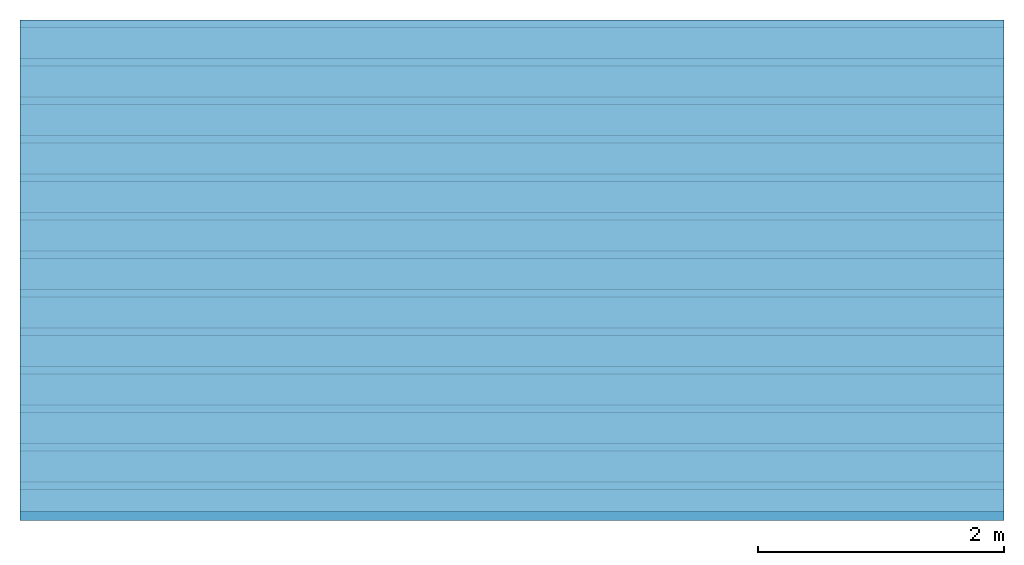
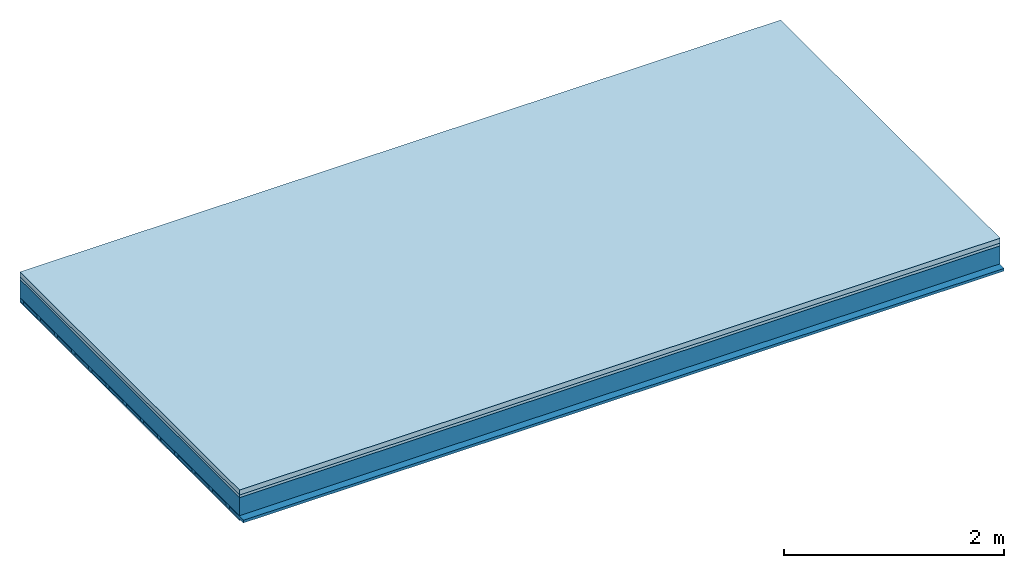
# One storey: 3 members, 3 plates, 1 element without a shape of its own.
"""IFC4 building model written with IfcOpenShell, lengths in metres."""

from ifc_helpers import new_model, si_unit, derived_unit, direction, frame, frame_2d, origin, origin_with_axes, place, context, project, spatial, rectangle, extrude, material, layer, layer_set, type_object, element, aggregate, save


model = new_model("IFC4")

# Units and contexts
plan_context = context("Plan", 3, precision=1e-05, world=origin(), true_north=direction((0.0, 1.0)))
model_context = context("Model", 3, precision=1e-05, world=origin(), true_north=direction((0.0, 1.0)))
ifc_project = project(units=[si_unit("LENGTHUNIT", "METRE"), derived_unit("SOUNDPRESSUREUNIT", [(si_unit("PRESSUREUNIT", "PASCAL", prefix="MICRO"), 0)]), si_unit("ENERGYUNIT", "JOULE", prefix="MEGA"), si_unit("MASSUNIT", "GRAM", prefix="KILO"), derived_unit("THERMALTRANSMITTANCEUNIT", [(si_unit("POWERUNIT", "WATT"), 1), (si_unit("AREAUNIT", "SQUARE_METRE"), -1), (si_unit("THERMODYNAMICTEMPERATUREUNIT", "KELVIN"), -1)]), derived_unit("AREADENSITYUNIT", [(si_unit("MASSUNIT", "GRAM", prefix="KILO"), 1), (si_unit("AREAUNIT", "SQUARE_METRE"), -1)]), derived_unit("USERDEFINED", [(si_unit("ENERGYUNIT", "JOULE", prefix="MEGA"), 1), (si_unit("AREAUNIT", "SQUARE_METRE"), -1)])], contexts=[plan_context, model_context])

# Site, building, storey
site = spatial("IfcSite", under=ifc_project)
building_placement = place(None, origin())
building = spatial("IfcBuilding", under=site, at=building_placement)
storey_placement = place(building_placement, origin())
storey = spatial("IfcBuildingStorey", under=building, at=storey_placement)

# Slab, members, plates
ifc_material_1 = material(Category="04.005")
ifc_layer_1 = layer(ifc_material_1, 0.055, Name="On-material")
ifc_material_2 = material()
ifc_layer_2 = layer(ifc_material_2, 0.03, Name="Impact sound insulation")
ifc_layer_3 = layer(None, 0.2, Name="Supporting structure")
ifc_material_3 = material(Name="of the art")
ifc_layer_4 = layer(ifc_material_3, 0.0, Name="Bond")
ifc_layer_5 = layer(None, 0.04, Name="Battens / profiles")
ifc_material_4 = material(Category="03.007")
ifc_layer_6 = layer(ifc_material_4, 0.015, Name="Ceiling covering 1st layer")
ifc_material_5 = material(Name="Glued joints")
ifc_layer_7 = layer(ifc_material_5, 0.0, Name="Surface / treatment")
ifc_layer_set = layer_set([ifc_layer_1, ifc_layer_2, ifc_layer_3, ifc_layer_4, ifc_layer_5, ifc_layer_6, ifc_layer_7])
slab_type = type_object("IfcSlabType", Name="A0849", PredefinedType="NOTDEFINED", material=ifc_layer_set)
slab_placement = place(None, frame((0.0, 0.0, 0.0), z_axis=(0.0, 0.0, -1.0), x_axis=(1.0, 0.0, 0.0)))
slab = element("IfcSlab", 1, at=slab_placement, inside=storey, type_object=slab_type, material=ifc_layer_set, Name="Slab #1")
ifc_material_6 = material()
member_1_placement = place(slab_placement, origin())
member_1 = element("IfcMember", 2, at=member_1_placement, material=ifc_material_6, Name="Supporting structure", context=plan_context, shape_type="SweptSolid", body=[
    extrude(rectangle(XDim=1.0, YDim=0.2, at=frame_2d((0.5, 0.1), x_axis=(1.0, 0.0))), frame((0.0, 4.0, 0.085), z_axis=(0.0, -1.0, 0.0), x_axis=(1.0, 0.0, 0.0)), (0.0, 0.0, 1.0), 4.0),
    extrude(rectangle(XDim=1.0, YDim=0.2, at=frame_2d((0.5, 0.1), x_axis=(1.0, 0.0))), frame((1.0, 4.0, 0.085), z_axis=(0.0, -1.0, 0.0), x_axis=(1.0, 0.0, 0.0)), (0.0, 0.0, 1.0), 4.0),
    extrude(rectangle(XDim=1.0, YDim=0.2, at=frame_2d((0.5, 0.1), x_axis=(1.0, 0.0))), frame((2.0, 4.0, 0.085), z_axis=(0.0, -1.0, 0.0), x_axis=(1.0, 0.0, 0.0)), (0.0, 0.0, 1.0), 4.0),
    extrude(rectangle(XDim=1.0, YDim=0.2, at=frame_2d((0.5, 0.1), x_axis=(1.0, 0.0))), frame((3.0, 4.0, 0.085), z_axis=(0.0, -1.0, 0.0), x_axis=(1.0, 0.0, 0.0)), (0.0, 0.0, 1.0), 4.0),
    extrude(rectangle(XDim=1.0, YDim=0.2, at=frame_2d((0.5, 0.1), x_axis=(1.0, 0.0))), frame((4.0, 4.0, 0.085), z_axis=(0.0, -1.0, 0.0), x_axis=(1.0, 0.0, 0.0)), (0.0, 0.0, 1.0), 4.0),
    extrude(rectangle(XDim=1.0, YDim=0.2, at=frame_2d((0.5, 0.1), x_axis=(1.0, 0.0))), frame((5.0, 4.0, 0.085), z_axis=(0.0, -1.0, 0.0), x_axis=(1.0, 0.0, 0.0)), (0.0, 0.0, 1.0), 4.0),
    extrude(rectangle(XDim=1.0, YDim=0.2, at=frame_2d((0.5, 0.1), x_axis=(1.0, 0.0))), frame((6.0, 4.0, 0.085), z_axis=(0.0, -1.0, 0.0), x_axis=(1.0, 0.0, 0.0)), (0.0, 0.0, 1.0), 4.0),
    extrude(rectangle(XDim=1.0, YDim=0.2, at=frame_2d((0.5, 0.1), x_axis=(1.0, 0.0))), frame((7.0, 4.0, 0.085), z_axis=(0.0, -1.0, 0.0), x_axis=(1.0, 0.0, 0.0)), (0.0, 0.0, 1.0), 4.0),
])
ifc_material_7 = material()
member_2_placement = place(slab_placement, origin())
member_2 = element("IfcMember", 3, at=member_2_placement, material=ifc_material_7, Name="Battens / profiles", context=plan_context, shape_type="SweptSolid", body=[
    extrude(rectangle(XDim=0.06, YDim=0.04, at=frame_2d((0.03, 0.02), x_axis=(1.0, 0.0))), frame((0.0, 0.0, 0.285), z_axis=(1.0, 0.0, 0.0), x_axis=(0.0, 1.0, 0.0)), (0.0, 0.0, 1.0), 8.0),
    extrude(rectangle(XDim=0.06, YDim=0.04, at=frame_2d((0.03, 0.02), x_axis=(1.0, 0.0))), frame((0.0, 0.313, 0.285), z_axis=(1.0, 0.0, 0.0), x_axis=(0.0, 1.0, 0.0)), (0.0, 0.0, 1.0), 8.0),
    extrude(rectangle(XDim=0.06, YDim=0.04, at=frame_2d((0.03, 0.02), x_axis=(1.0, 0.0))), frame((0.0, 0.626, 0.285), z_axis=(1.0, 0.0, 0.0), x_axis=(0.0, 1.0, 0.0)), (0.0, 0.0, 1.0), 8.0),
    extrude(rectangle(XDim=0.06, YDim=0.04, at=frame_2d((0.03, 0.02), x_axis=(1.0, 0.0))), frame((0.0, 0.939, 0.285), z_axis=(1.0, 0.0, 0.0), x_axis=(0.0, 1.0, 0.0)), (0.0, 0.0, 1.0), 8.0),
    extrude(rectangle(XDim=0.06, YDim=0.04, at=frame_2d((0.03, 0.02), x_axis=(1.0, 0.0))), frame((0.0, 1.252, 0.285), z_axis=(1.0, 0.0, 0.0), x_axis=(0.0, 1.0, 0.0)), (0.0, 0.0, 1.0), 8.0),
    extrude(rectangle(XDim=0.06, YDim=0.04, at=frame_2d((0.03, 0.02), x_axis=(1.0, 0.0))), frame((0.0, 1.565, 0.285), z_axis=(1.0, 0.0, 0.0), x_axis=(0.0, 1.0, 0.0)), (0.0, 0.0, 1.0), 8.0),
    extrude(rectangle(XDim=0.06, YDim=0.04, at=frame_2d((0.03, 0.02), x_axis=(1.0, 0.0))), frame((0.0, 1.878, 0.285), z_axis=(1.0, 0.0, 0.0), x_axis=(0.0, 1.0, 0.0)), (0.0, 0.0, 1.0), 8.0),
    extrude(rectangle(XDim=0.06, YDim=0.04, at=frame_2d((0.03, 0.02), x_axis=(1.0, 0.0))), frame((0.0, 2.191, 0.285), z_axis=(1.0, 0.0, 0.0), x_axis=(0.0, 1.0, 0.0)), (0.0, 0.0, 1.0), 8.0),
    extrude(rectangle(XDim=0.06, YDim=0.04, at=frame_2d((0.03, 0.02), x_axis=(1.0, 0.0))), frame((0.0, 2.504, 0.285), z_axis=(1.0, 0.0, 0.0), x_axis=(0.0, 1.0, 0.0)), (0.0, 0.0, 1.0), 8.0),
    extrude(rectangle(XDim=0.06, YDim=0.04, at=frame_2d((0.03, 0.02), x_axis=(1.0, 0.0))), frame((0.0, 2.817, 0.285), z_axis=(1.0, 0.0, 0.0), x_axis=(0.0, 1.0, 0.0)), (0.0, 0.0, 1.0), 8.0),
    extrude(rectangle(XDim=0.06, YDim=0.04, at=frame_2d((0.03, 0.02), x_axis=(1.0, 0.0))), frame((0.0, 3.13, 0.285), z_axis=(1.0, 0.0, 0.0), x_axis=(0.0, 1.0, 0.0)), (0.0, 0.0, 1.0), 8.0),
    extrude(rectangle(XDim=0.06, YDim=0.04, at=frame_2d((0.03, 0.02), x_axis=(1.0, 0.0))), frame((0.0, 3.443, 0.285), z_axis=(1.0, 0.0, 0.0), x_axis=(0.0, 1.0, 0.0)), (0.0, 0.0, 1.0), 8.0),
    extrude(rectangle(XDim=0.06, YDim=0.04, at=frame_2d((0.03, 0.02), x_axis=(1.0, 0.0))), frame((0.0, 3.756, 0.285), z_axis=(1.0, 0.0, 0.0), x_axis=(0.0, 1.0, 0.0)), (0.0, 0.0, 1.0), 8.0),
])
ifc_material_8 = material()
member_3_placement = place(slab_placement, origin())
member_3 = element("IfcMember", 4, at=member_3_placement, material=ifc_material_8, Name="Cavity", context=plan_context, shape_type="SweptSolid", body=[
    extrude(rectangle(XDim=0.253, YDim=0.03, at=frame_2d((0.1265, 0.015), x_axis=(1.0, 0.0))), frame((0.0, 0.06, 0.295), z_axis=(1.0, 0.0, 0.0), x_axis=(0.0, 1.0, 0.0)), (0.0, 0.0, 1.0), 8.0),
    extrude(rectangle(XDim=0.253, YDim=0.03, at=frame_2d((0.1265, 0.015), x_axis=(1.0, 0.0))), frame((0.0, 0.373, 0.295), z_axis=(1.0, 0.0, 0.0), x_axis=(0.0, 1.0, 0.0)), (0.0, 0.0, 1.0), 8.0),
    extrude(rectangle(XDim=0.253, YDim=0.03, at=frame_2d((0.1265, 0.015), x_axis=(1.0, 0.0))), frame((0.0, 0.686, 0.295), z_axis=(1.0, 0.0, 0.0), x_axis=(0.0, 1.0, 0.0)), (0.0, 0.0, 1.0), 8.0),
    extrude(rectangle(XDim=0.253, YDim=0.03, at=frame_2d((0.1265, 0.015), x_axis=(1.0, 0.0))), frame((0.0, 0.999, 0.295), z_axis=(1.0, 0.0, 0.0), x_axis=(0.0, 1.0, 0.0)), (0.0, 0.0, 1.0), 8.0),
    extrude(rectangle(XDim=0.253, YDim=0.03, at=frame_2d((0.1265, 0.015), x_axis=(1.0, 0.0))), frame((0.0, 1.312, 0.295), z_axis=(1.0, 0.0, 0.0), x_axis=(0.0, 1.0, 0.0)), (0.0, 0.0, 1.0), 8.0),
    extrude(rectangle(XDim=0.253, YDim=0.03, at=frame_2d((0.1265, 0.015), x_axis=(1.0, 0.0))), frame((0.0, 1.625, 0.295), z_axis=(1.0, 0.0, 0.0), x_axis=(0.0, 1.0, 0.0)), (0.0, 0.0, 1.0), 8.0),
    extrude(rectangle(XDim=0.253, YDim=0.03, at=frame_2d((0.1265, 0.015), x_axis=(1.0, 0.0))), frame((0.0, 1.938, 0.295), z_axis=(1.0, 0.0, 0.0), x_axis=(0.0, 1.0, 0.0)), (0.0, 0.0, 1.0), 8.0),
    extrude(rectangle(XDim=0.253, YDim=0.03, at=frame_2d((0.1265, 0.015), x_axis=(1.0, 0.0))), frame((0.0, 2.251, 0.295), z_axis=(1.0, 0.0, 0.0), x_axis=(0.0, 1.0, 0.0)), (0.0, 0.0, 1.0), 8.0),
    extrude(rectangle(XDim=0.253, YDim=0.03, at=frame_2d((0.1265, 0.015), x_axis=(1.0, 0.0))), frame((0.0, 2.564, 0.295), z_axis=(1.0, 0.0, 0.0), x_axis=(0.0, 1.0, 0.0)), (0.0, 0.0, 1.0), 8.0),
    extrude(rectangle(XDim=0.253, YDim=0.03, at=frame_2d((0.1265, 0.015), x_axis=(1.0, 0.0))), frame((0.0, 2.877, 0.295), z_axis=(1.0, 0.0, 0.0), x_axis=(0.0, 1.0, 0.0)), (0.0, 0.0, 1.0), 8.0),
    extrude(rectangle(XDim=0.253, YDim=0.03, at=frame_2d((0.1265, 0.015), x_axis=(1.0, 0.0))), frame((0.0, 3.19, 0.295), z_axis=(1.0, 0.0, 0.0), x_axis=(0.0, 1.0, 0.0)), (0.0, 0.0, 1.0), 8.0),
    extrude(rectangle(XDim=0.253, YDim=0.03, at=frame_2d((0.1265, 0.015), x_axis=(1.0, 0.0))), frame((0.0, 3.503, 0.295), z_axis=(1.0, 0.0, 0.0), x_axis=(0.0, 1.0, 0.0)), (0.0, 0.0, 1.0), 8.0),
    extrude(rectangle(XDim=0.253, YDim=0.03, at=frame_2d((0.1265, 0.015), x_axis=(1.0, 0.0))), frame((0.0, 3.816, 0.295), z_axis=(1.0, 0.0, 0.0), x_axis=(0.0, 1.0, 0.0)), (0.0, 0.0, 1.0), 8.0),
])
plate_1_placement = place(slab_placement, origin())
plate_1 = element("IfcPlate", 5, at=plate_1_placement, material=ifc_material_1, Name="On-material", context=plan_context, shape_type="SweptSolid", body=[
    extrude(rectangle(XDim=8.0, YDim=4.0, at=frame_2d((4.0, 2.0), x_axis=(1.0, 0.0))), origin_with_axes(), (0.0, 0.0, 1.0), 0.055),
])
plate_2_placement = place(slab_placement, origin())
plate_2 = element("IfcPlate", 6, at=plate_2_placement, material=ifc_material_2, Name="Impact sound insulation", context=plan_context, shape_type="SweptSolid", body=[
    extrude(rectangle(XDim=8.0, YDim=4.0, at=frame_2d((4.0, 2.0), x_axis=(1.0, 0.0))), frame((0.0, 0.0, 0.055), z_axis=(0.0, 0.0, 1.0), x_axis=(1.0, 0.0, 0.0)), (0.0, 0.0, 1.0), 0.03),
])
plate_3_placement = place(slab_placement, origin())
plate_3 = element("IfcPlate", 7, at=plate_3_placement, material=ifc_material_4, Name="Ceiling covering 1st layer", context=plan_context, shape_type="SweptSolid", body=[
    extrude(rectangle(XDim=8.0, YDim=4.0, at=frame_2d((4.0, 2.0), x_axis=(1.0, 0.0))), frame((0.0, 0.0, 0.325), z_axis=(0.0, 0.0, 1.0), x_axis=(1.0, 0.0, 0.0)), (0.0, 0.0, 1.0), 0.015),
])
aggregate(slab, [plate_1, plate_2, member_1, member_2, member_3, plate_3])

save(model, "model.ifc")
